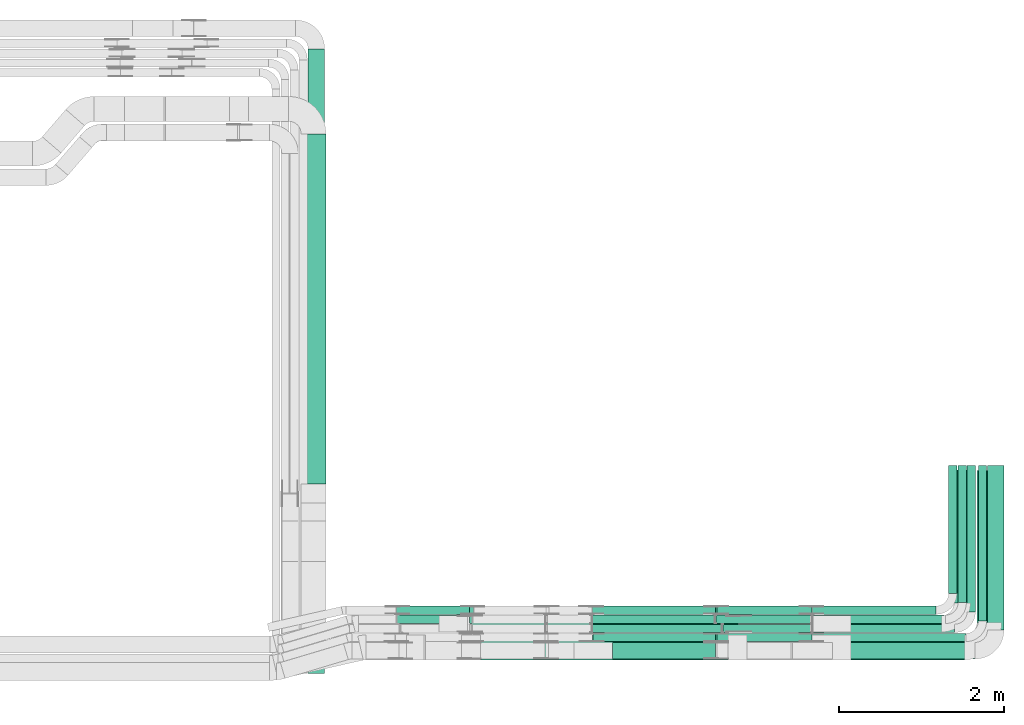
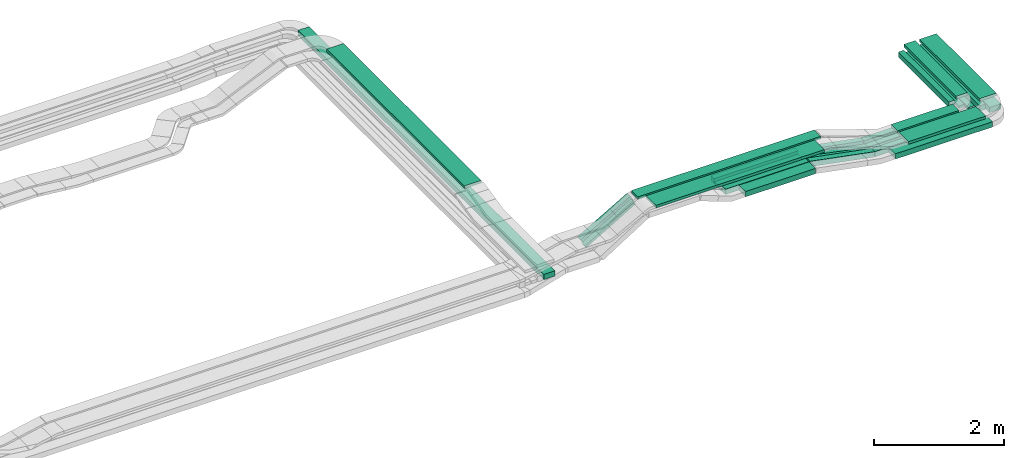
# One storey, part 3 of 31: 29 flow segments.
"""IFC2X3 building model written with IfcOpenShell, lengths in millimetres."""

from ifc_helpers import new_model, entity, si_unit, converted_unit, derived_unit, direction, frame, frame_2d, origin, origin_2d_with_axis, place, context, subcontext, project, spatial, rectangle, extrude, type_object, element, save


model = new_model("IFC2X3")

# Units and contexts
model_context = context("Model", 3, precision=0.01, world=origin(), true_north=direction((6.12303176911189e-17, 1.0)))
body_context = subcontext(model_context, "Body", "Model", "MODEL_VIEW")
ifc_project = project(units=[si_unit("LENGTHUNIT", "METRE", prefix="MILLI"), si_unit("AREAUNIT", "SQUARE_METRE"), si_unit("VOLUMEUNIT", "CUBIC_METRE"), converted_unit("PLANEANGLEUNIT", "DEGREE", entity("IfcRatioMeasure", 0.0174532925199433), si_unit("PLANEANGLEUNIT", "RADIAN"), dimensions=[0, 0, 0, 0, 0, 0, 0]), si_unit("MASSUNIT", "GRAM", prefix="KILO"), derived_unit("MASSDENSITYUNIT", [(si_unit("MASSUNIT", "GRAM", prefix="KILO"), 1), (si_unit("LENGTHUNIT", "METRE"), -3)]), derived_unit("MOMENTOFINERTIAUNIT", [(si_unit("LENGTHUNIT", "METRE"), 4)]), si_unit("TIMEUNIT", "SECOND"), si_unit("FREQUENCYUNIT", "HERTZ"), si_unit("THERMODYNAMICTEMPERATUREUNIT", "DEGREE_CELSIUS"), derived_unit("THERMALTRANSMITTANCEUNIT", [(si_unit("MASSUNIT", "GRAM", prefix="KILO"), 1), (si_unit("THERMODYNAMICTEMPERATUREUNIT", "KELVIN"), -1), (si_unit("TIMEUNIT", "SECOND"), -3)]), derived_unit("VOLUMETRICFLOWRATEUNIT", [(si_unit("LENGTHUNIT", "METRE"), 3), (si_unit("TIMEUNIT", "SECOND"), -1)]), derived_unit("MASSFLOWRATEUNIT", [(si_unit("MASSUNIT", "GRAM", prefix="KILO"), 1), (si_unit("TIMEUNIT", "SECOND"), -1)]), derived_unit("ROTATIONALFREQUENCYUNIT", [(si_unit("TIMEUNIT", "SECOND"), -1)]), si_unit("ELECTRICCURRENTUNIT", "AMPERE"), si_unit("ELECTRICVOLTAGEUNIT", "VOLT"), si_unit("POWERUNIT", "WATT"), si_unit("FORCEUNIT", "NEWTON", prefix="KILO"), si_unit("ILLUMINANCEUNIT", "LUX"), si_unit("LUMINOUSFLUXUNIT", "LUMEN"), si_unit("LUMINOUSINTENSITYUNIT", "CANDELA"), derived_unit("USERDEFINED", [(si_unit("MASSUNIT", "GRAM", prefix="KILO"), -1), (si_unit("LENGTHUNIT", "METRE"), -2), (si_unit("TIMEUNIT", "SECOND"), 3), (si_unit("LUMINOUSFLUXUNIT", "LUMEN"), 1)]), derived_unit("LINEARVELOCITYUNIT", [(si_unit("LENGTHUNIT", "METRE"), 1), (si_unit("TIMEUNIT", "SECOND"), -1)]), si_unit("PRESSUREUNIT", "PASCAL"), derived_unit("USERDEFINED", [(si_unit("LENGTHUNIT", "METRE"), -2), (si_unit("MASSUNIT", "GRAM", prefix="KILO"), 1), (si_unit("TIMEUNIT", "SECOND"), -2)]), derived_unit("LINEARFORCEUNIT", [(si_unit("MASSUNIT", "GRAM", prefix="KILO"), 1), (si_unit("LENGTHUNIT", "METRE"), 1), (si_unit("TIMEUNIT", "SECOND"), -2), (si_unit("LENGTHUNIT", "METRE"), -1)]), derived_unit("PLANARFORCEUNIT", [(si_unit("MASSUNIT", "GRAM", prefix="KILO"), 1), (si_unit("LENGTHUNIT", "METRE"), 1), (si_unit("TIMEUNIT", "SECOND"), -2), (si_unit("LENGTHUNIT", "METRE"), -2)])], contexts=[model_context])

# Site, building, storey
site_placement = place(None, frame((0.0, -0.00077364408347762, 0.0)))
site = spatial("IfcSite", under=ifc_project, at=site_placement, CompositionType="ELEMENT")
building_placement = place(site_placement, origin())
building = spatial("IfcBuilding", under=site, at=building_placement, CompositionType="ELEMENT")
storey_placement = place(building_placement, frame((0.0, 0.0, 15900.0)))
storey = spatial("IfcBuildingStorey", under=building, at=storey_placement, CompositionType="ELEMENT", Elevation=15900.0)

# Flow segments
cable_carrier_segment_type = type_object("IfcCableCarrierSegmentType", PredefinedType="CABLETRAYSEGMENT")
flow_segment_1_placement = place(storey_placement, frame((66666.2650951491, 8904.96586239506, 2595.87316402394)))
element("IfcFlowSegment", 1, at=flow_segment_1_placement, inside=storey, type_object=cable_carrier_segment_type, context=body_context, shape_type="SweptSolid", body=[
    extrude(rectangle(XDim=1605.67956376244, YDim=99.9999999999989, at=frame_2d((-4.32009983342141e-12, 5.40012479177676e-13), x_axis=(1.0, 0.0))), frame((802.839781881225, 50.0, 0.0), z_axis=(0.0, 0.0, 1.0), x_axis=(-1.0, 0.0, 0.0)), (0.0, 0.0, 1.0), 49.9999999999995),
])
flow_segment_2_placement = place(storey_placement, frame((66901.6891186176, 8474.9658623949, 2595.87316402393)))
element("IfcFlowSegment", 2, at=flow_segment_2_placement, inside=storey, type_object=cable_carrier_segment_type, context=body_context, shape_type="SweptSolid", body=[
    extrude(rectangle(XDim=1725.25554029387, YDim=200.0, at=frame_2d((4.32009983342141e-12, 0.0), x_axis=(1.0, 0.0))), frame((862.627770146939, 100.0, 0.0), z_axis=(0.0, 0.0, 1.0), x_axis=(-1.0, 0.0, 0.0)), (0.0, 0.0, 1.0), 99.9999999999989),
])
flow_segment_3_placement = place(storey_placement, frame((67129.5678484081, 8465.14842319132, 2800.87316402393)))
element("IfcFlowSegment", 3, at=flow_segment_3_placement, inside=storey, type_object=cable_carrier_segment_type, context=body_context, shape_type="SweptSolid", body=[
    extrude(rectangle(XDim=1369.62953868622, YDim=300.000000000001, at=frame_2d((-4.32009983342141e-12, -1.08002495835535e-12), x_axis=(1.0, 0.0))), frame((684.814769343113, 150.0, 0.0)), (0.0, 0.0, 1.0), 50.0000000000016),
])
flow_segment_4_placement = place(storey_placement, frame((62523.0201003251, 8800.14842319195, 3175.0)))
element("IfcFlowSegment", 4, at=flow_segment_4_placement, inside=storey, type_object=cable_carrier_segment_type, context=body_context, shape_type="SweptSolid", body=[
    extrude(rectangle(XDim=3245.01675058186, YDim=200.0, at=frame_2d((-8.64019966684282e-12, 5.47117906535277e-13), x_axis=(1.0, 0.0))), frame((1622.50837529094, 100.0, 0.0)), (0.0, 0.0, 1.0), 49.9999999999995),
])
flow_segment_5_placement = place(storey_placement, frame((62649.8093141622, 8465.14842319196, 3175.0)))
element("IfcFlowSegment", 5, at=flow_segment_5_placement, inside=storey, type_object=cable_carrier_segment_type, context=body_context, shape_type="SweptSolid", body=[
    extrude(rectangle(XDim=2990.04095154965, YDim=299.999999999999, at=frame_2d((-4.32009983342141e-12, 0.0), x_axis=(1.0, 0.0))), frame((1495.02047577483, 150.0, 0.0)), (0.0, 0.0, 1.0), 50.0000000000016),
])
flow_segment_6_placement = place(storey_placement, frame((66660.3243374075, 9014.96586239505, 2595.87316402393)))
element("IfcFlowSegment", 6, at=flow_segment_6_placement, inside=storey, type_object=cable_carrier_segment_type, context=body_context, shape_type="SweptSolid", body=[
    extrude(rectangle(XDim=1496.62032150407, YDim=99.9999999999989, at=frame_2d((0.0, 5.40012479177676e-13), x_axis=(1.0, 0.0))), frame((748.310160752033, 50.0, 0.0), z_axis=(0.0, 0.0, 1.0), x_axis=(-1.0, 0.0, 0.0)), (0.0, 0.0, 1.0), 99.9999999999989),
])
flow_segment_7_placement = place(storey_placement, frame((66666.6246909035, 8794.96586239506, 2595.87316402394)))
element("IfcFlowSegment", 7, at=flow_segment_7_placement, inside=storey, type_object=cable_carrier_segment_type, context=body_context, shape_type="SweptSolid", body=[
    extrude(rectangle(XDim=1715.31996800804, YDim=99.9999999999989, at=frame_2d((-4.32009983342141e-12, 0.0), x_axis=(1.0, 0.0))), frame((857.659984004023, 50.0, 0.0), z_axis=(0.0, 0.0, 1.0), x_axis=(-1.0, 0.0, 0.0)), (0.0, 0.0, 1.0), 50.0000000000016),
])
flow_segment_8_placement = place(storey_placement, frame((66660.3243374075, 8684.96586239498, 2595.87316402393)))
element("IfcFlowSegment", 8, at=flow_segment_8_placement, inside=storey, type_object=cable_carrier_segment_type, context=body_context, shape_type="SweptSolid", body=[
    extrude(rectangle(XDim=1856.62032150398, YDim=99.9999999999989, at=frame_2d((0.0, 5.40012479177676e-13), x_axis=(1.0, 0.0))), frame((928.310160751992, 50.0, 0.0), z_axis=(0.0, 0.0, 1.0), x_axis=(-1.0, 0.0, 0.0)), (0.0, 0.0, 1.0), 99.9999999999989),
])
flow_segment_9_placement = place(storey_placement, frame((68650.1973870943, 8916.14842319132, 2800.87316402393)))
element("IfcFlowSegment", 9, at=flow_segment_9_placement, inside=storey, type_object=cable_carrier_segment_type, context=body_context, shape_type="SweptSolid", body=[
    extrude(rectangle(XDim=1839.00000000001, YDim=300.000000000001, at=frame_2d((-5.6843418860808e-13, -4.33431068813661e-12), x_axis=(1.0, 0.0))), frame((150.0, 919.500000000005, 0.0), z_axis=(0.0, 0.0, 1.0), x_axis=(0.0, 1.0, 0.0)), (0.0, 0.0, 1.0), 50.0000000000038),
])
flow_segment_10_placement = place(storey_placement, frame((67129.7259886642, 8800.14842319194, 2800.87316402393)))
element("IfcFlowSegment", 10, at=flow_segment_10_placement, inside=storey, type_object=cable_carrier_segment_type, context=body_context, shape_type="SweptSolid", body=[
    extrude(rectangle(XDim=1092.21867024738, YDim=200.0, at=origin_2d_with_axis()), frame((546.109335123692, 100.0, 0.0)), (0.0, 0.0, 1.0), 50.0000000000016),
])
flow_segment_11_placement = place(storey_placement, frame((68372.9446589116, 9151.14842319194, 2800.87316402393)))
element("IfcFlowSegment", 11, at=flow_segment_11_placement, inside=storey, type_object=cable_carrier_segment_type, context=body_context, shape_type="SweptSolid", body=[
    extrude(rectangle(XDim=1609.00000000001, YDim=200.000000000007, at=frame_2d((1.08002495835535e-12, 0.0), x_axis=(1.0, 0.0))), frame((100.0, 804.500000000004, 0.0), z_axis=(0.0, 0.0, 1.0), x_axis=(0.0, 1.0, 0.0)), (0.0, 0.0, 1.0), 50.0000000000016),
])
flow_segment_12_placement = place(storey_placement, frame((60566.0767428682, 8299.99390899457, 2660.0)))
element("IfcFlowSegment", 12, at=flow_segment_12_placement, inside=storey, type_object=cable_carrier_segment_type, context=body_context, shape_type="SweptSolid", body=[
    extrude(rectangle(XDim=7549.00000000001, YDim=200.000000000007, at=frame_2d((0.0, 8.66862137627322e-12), x_axis=(1.0, 0.0))), frame((100.0, 3774.50000000001, 0.0), z_axis=(0.0, 0.0, 1.0), x_axis=(0.0, -1.0, 0.0)), (0.0, 0.0, 1.0), 99.9999999999989),
])
flow_segment_13_placement = place(storey_placement, frame((60480.8175590596, 10591.0702493114, 3010.0)))
element("IfcFlowSegment", 13, at=flow_segment_13_placement, inside=storey, type_object=cable_carrier_segment_type, context=body_context, shape_type="SweptSolid", body=[
    extrude(rectangle(XDim=4232.95525920249, YDim=300.000000000001, at=origin_2d_with_axis()), frame((150.0, 2116.47762960124, 0.0), z_axis=(0.0, 0.0, 1.0), x_axis=(0.0, -1.0, 0.0)), (0.0, 0.0, 1.0), 50.0000000000016),
])
flow_segment_14_placement = place(storey_placement, frame((61642.549433409, 8904.96586239507, 2505.41277076195)))
element("IfcFlowSegment", 14, at=flow_segment_14_placement, inside=storey, type_object=cable_carrier_segment_type, context=body_context, shape_type="SweptSolid", body=[
    extrude(rectangle(XDim=49.9999999999998, YDim=100.000000000001, at=frame_2d((2.79776202205539e-12, 1.08357767203415e-12), x_axis=(1.0, 0.0))), frame((12.6948449319701, 50.0, 21.5369661780237), z_axis=(0.861478647120952, 0.0, 0.507793797278634), x_axis=(-0.507793797278634, 0.0, 0.861478647120952)), (0.0, 0.0, 1.0), 1017.26176000681),
])
flow_segment_15_placement = place(storey_placement, frame((61634.2524900703, 9014.96586239506, 2514.44731498032)))
element("IfcFlowSegment", 15, at=flow_segment_15_placement, inside=storey, type_object=cable_carrier_segment_type, context=body_context, shape_type="SweptSolid", body=[
    extrude(rectangle(XDim=99.999999999997, YDim=100.000000000001, at=frame_2d((0.0, 1.08357767203415e-12), x_axis=(1.0, 0.0))), frame((25.0114283900799, 50.0, 43.2946699939814), z_axis=(0.865893399879655, 0.0, 0.500228567801613), x_axis=(-0.500228567801613, 0.0, 0.865893399879655)), (0.0, 0.0, 1.0), 1019.43607262712),
])
flow_segment_16_placement = place(storey_placement, frame((68307.9446589116, 9265.96586239506, 2595.87316402394)))
element("IfcFlowSegment", 16, at=flow_segment_16_placement, inside=storey, type_object=cable_carrier_segment_type, context=body_context, shape_type="SweptSolid", body=[
    extrude(rectangle(XDim=1548.99999999986, YDim=99.9999999999946, at=frame_2d((-1.08002495835535e-12, -4.33075797445781e-12), x_axis=(1.0, 0.0))), frame((50.0, 774.499999999929, 0.0), z_axis=(0.0, 0.0, 1.0), x_axis=(0.0, 1.0, 0.0)), (0.0, 0.0, 1.0), 99.9999999999968),
])
flow_segment_17_placement = place(storey_placement, frame((68422.9446589116, 9155.96586239506, 2595.87316402394)))
element("IfcFlowSegment", 17, at=flow_segment_17_placement, inside=storey, type_object=cable_carrier_segment_type, context=body_context, shape_type="SweptSolid", body=[
    extrude(rectangle(XDim=1658.99999999985, YDim=99.9999999999946, at=frame_2d((-1.64845914696343e-12, 0.0), x_axis=(1.0, 0.0))), frame((50.0, 829.499999999931, 0.0), z_axis=(0.0, 0.0, 1.0), x_axis=(0.0, 1.0, 0.0)), (0.0, 0.0, 1.0), 50.0000000000016),
])
flow_segment_18_placement = place(storey_placement, frame((68532.9446589116, 9045.96586239507, 2595.87316402394)))
element("IfcFlowSegment", 18, at=flow_segment_18_placement, inside=storey, type_object=cable_carrier_segment_type, context=body_context, shape_type="SweptSolid", body=[
    extrude(rectangle(XDim=1768.99999999985, YDim=99.9999999999946, at=frame_2d((1.08002495835535e-12, 0.0), x_axis=(1.0, 0.0))), frame((50.0, 884.499999999926, 0.0), z_axis=(0.0, 0.0, 1.0), x_axis=(0.0, 1.0, 0.0)), (0.0, 0.0, 1.0), 50.0000000000016),
])
flow_segment_19_placement = place(storey_placement, frame((68667.9446589115, 8935.96586239499, 2595.87316402394)))
element("IfcFlowSegment", 19, at=flow_segment_19_placement, inside=storey, type_object=cable_carrier_segment_type, context=body_context, shape_type="SweptSolid", body=[
    extrude(rectangle(XDim=1878.99999999993, YDim=99.9999999999946, at=frame_2d((-1.13686837721616e-12, 0.0), x_axis=(1.0, 0.0))), frame((50.0, 939.499999999967, 0.0), z_axis=(0.0, 0.0, 1.0), x_axis=(0.0, 1.0, 0.0)), (0.0, 0.0, 1.0), 99.9999999999989),
])
flow_segment_20_placement = place(storey_placement, frame((68777.9446589115, 8825.96586239491, 2595.87316402394)))
element("IfcFlowSegment", 20, at=flow_segment_20_placement, inside=storey, type_object=cable_carrier_segment_type, context=body_context, shape_type="SweptSolid", body=[
    extrude(rectangle(XDim=1989.00000000001, YDim=200.000000000007, at=frame_2d((-5.11590769747272e-13, 0.0), x_axis=(1.0, 0.0))), frame((100.0, 994.500000000004, 0.0), z_axis=(0.0, 0.0, 1.0), x_axis=(0.0, 1.0, 0.0)), (0.0, 0.0, 1.0), 99.9999999999989),
])
flow_segment_21_placement = place(storey_placement, frame((64002.2584894005, 8904.96586239505, 2818.48004652783)))
element("IfcFlowSegment", 21, at=flow_segment_21_placement, inside=storey, type_object=cable_carrier_segment_type, context=body_context, shape_type="SweptSolid", body=[
    extrude(rectangle(XDim=1481.27373216724, YDim=100.000000000001, at=frame_2d((0.0, -5.43565192856477e-13), x_axis=(1.0, 0.0))), frame((740.636866083618, 50.0, 0.0)), (0.0, 0.0, 1.0), 50.0000000000016),
])
flow_segment_22_placement = place(storey_placement, frame((64002.1869125145, 8794.96586239505, 2818.48004652782)))
element("IfcFlowSegment", 22, at=flow_segment_22_placement, inside=storey, type_object=cable_carrier_segment_type, context=body_context, shape_type="SweptSolid", body=[
    extrude(rectangle(XDim=1565.90224789294, YDim=99.9999999999989, at=frame_2d((-4.37694325228222e-12, 5.40012479177676e-13), x_axis=(1.0, 0.0))), frame((782.951123946473, 50.0, 0.0)), (0.0, 0.0, 1.0), 50.0000000000016),
])
flow_segment_23_placement = place(storey_placement, frame((64008.2342085597, 8684.96586239497, 2818.48004652781)))
element("IfcFlowSegment", 23, at=flow_segment_23_placement, inside=storey, type_object=cable_carrier_segment_type, context=body_context, shape_type="SweptSolid", body=[
    extrude(rectangle(XDim=1481.28976278367, YDim=100.000000000001, at=frame_2d((0.0, 5.43565192856477e-13), x_axis=(1.0, 0.0))), frame((740.644881391833, 50.0, 0.0)), (0.0, 0.0, 1.0), 99.9999999999989),
])
flow_segment_24_placement = place(storey_placement, frame((64246.7486213509, 8474.9658623949, 2818.48004652783)))
element("IfcFlowSegment", 24, at=flow_segment_24_placement, inside=storey, type_object=cable_carrier_segment_type, context=body_context, shape_type="SweptSolid", body=[
    extrude(rectangle(XDim=1242.77534999253, YDim=200.0, at=frame_2d((-8.69704308570363e-12, 0.0), x_axis=(1.0, 0.0))), frame((621.387674996293, 100.0, 0.0)), (0.0, 0.0, 1.0), 99.9999999999989),
])
flow_segment_25_placement = place(storey_placement, frame((64001.6808696971, 9014.96586239505, 2818.48004652781)))
element("IfcFlowSegment", 25, at=flow_segment_25_placement, inside=storey, type_object=cable_carrier_segment_type, context=body_context, shape_type="SweptSolid", body=[
    extrude(rectangle(XDim=1487.84310164632, YDim=100.000000000001, at=frame_2d((0.0, -5.43565192856477e-13), x_axis=(1.0, 0.0))), frame((743.92155082316, 50.0, 0.0)), (0.0, 0.0, 1.0), 99.9999999999989),
])
flow_segment_26_placement = place(storey_placement, frame((65492.2607911448, 8684.96586239497, 2597.93016431392)))
element("IfcFlowSegment", 26, at=flow_segment_26_placement, inside=storey, type_object=cable_carrier_segment_type, context=body_context, shape_type="SweptSolid", body=[
    extrude(rectangle(XDim=100.000000000002, YDim=100.000000000001, at=origin_2d_with_axis()), frame((9.43480331321848, 50.0, 269.391105108412), z_axis=(0.982035536310349, 0.0, -0.188696066264366), x_axis=(0.188696066264366, 0.0, 0.982035536310349)), (0.0, 0.0, 1.0), 1167.42936222278),
])
flow_segment_27_placement = place(storey_placement, frame((65573.0985636469, 8794.96586239506, 2597.39423566586)))
element("IfcFlowSegment", 27, at=flow_segment_27_placement, inside=storey, type_object=cable_carrier_segment_type, context=body_context, shape_type="SweptSolid", body=[
    extrude(rectangle(XDim=50.0000000000034, YDim=99.9999999999989, at=origin_2d_with_axis()), frame((5.00940323956202, 50.0, 245.071763100701), z_axis=(0.979719044774343, 0.0, -0.200376129582467), x_axis=(0.200376129582467, 0.0, 0.979719044774343)), (0.0, 0.0, 1.0), 1100.82367316467),
])
flow_segment_28_placement = place(storey_placement, frame((65488.1921523119, 8904.96586239506, 2597.18757921162)))
element("IfcFlowSegment", 28, at=flow_segment_28_placement, inside=storey, type_object=cable_carrier_segment_type, context=body_context, shape_type="SweptSolid", body=[
    extrude(rectangle(XDim=49.9999999999982, YDim=100.000000000001, at=origin_2d_with_axis()), frame((4.65993074420253, 50.0, 245.41619052444), z_axis=(0.982474464164288, 0.0, -0.186397229767761), x_axis=(0.186397229767761, 0.0, 0.982474464164288)), (0.0, 0.0, 1.0), 1184.85842947056),
])
flow_segment_29_placement = place(storey_placement, frame((65492.2607911448, 9014.96586239505, 2597.93016431393)))
element("IfcFlowSegment", 29, at=flow_segment_29_placement, inside=storey, type_object=cable_carrier_segment_type, context=body_context, shape_type="SweptSolid", body=[
    extrude(rectangle(XDim=100.000000000002, YDim=99.9999999999989, at=origin_2d_with_axis()), frame((9.43480331321848, 50.0, 269.391105108408), z_axis=(0.982035536310349, 0.0, -0.188696066264366), x_axis=(0.188696066264366, 0.0, 0.982035536310349)), (0.0, 0.0, 1.0), 1167.42936222277),
])

save(model, "model.ifc")
